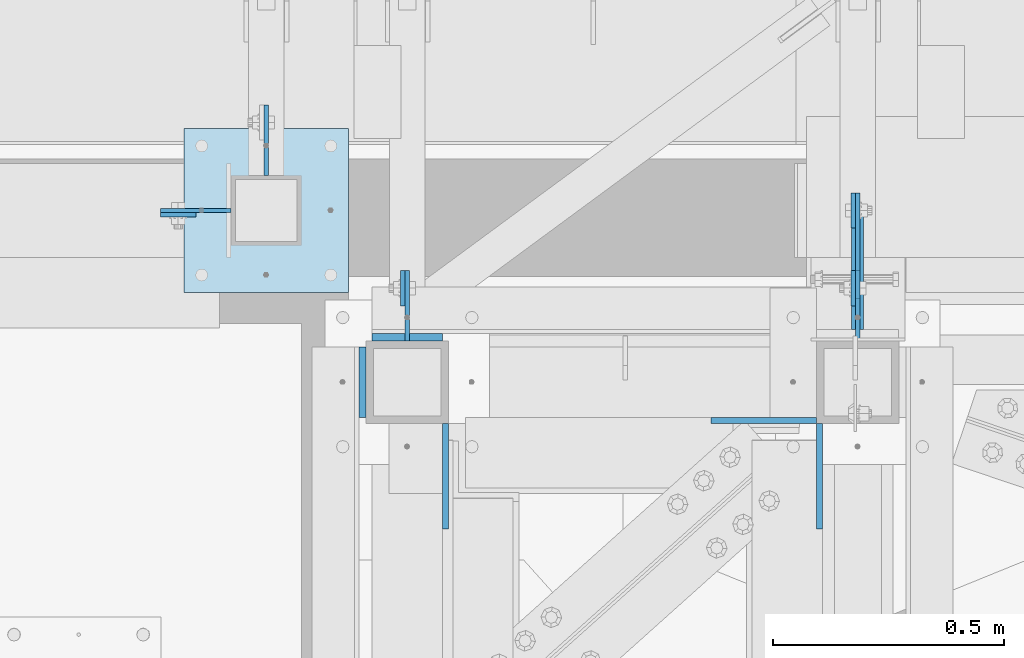
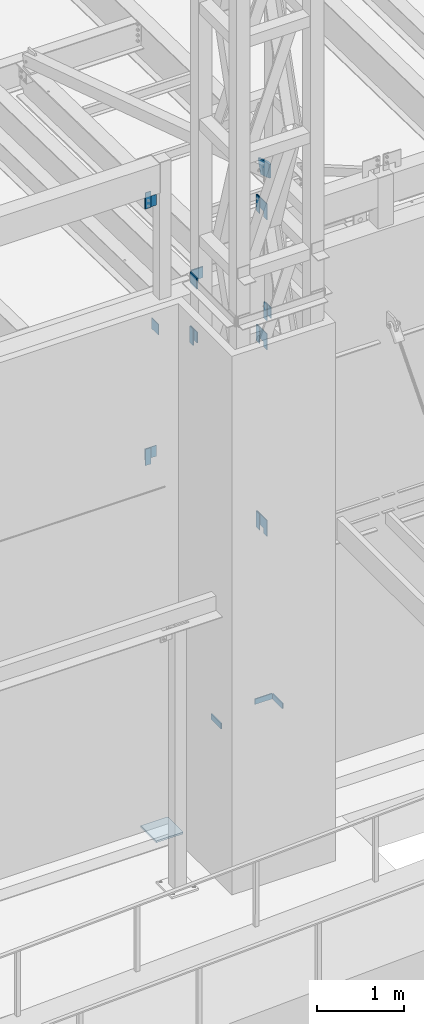
# One storey, part 1449 of 1763: 22 plates, 9 elements without a shape of their own.
"""IFC2X3 building model written with IfcOpenShell, lengths in millimetres."""

from ifc_helpers import new_model, si_unit, frame, origin_with_axes, place, context, subcontext, project, spatial, faceted_brep, material, type_object, element, aggregate, save


model = new_model("IFC2X3")

# Units and contexts
model_context = context("Model", 3, precision=1e-05, world=origin_with_axes())
body_context = subcontext(model_context, "Body", "Model", "MODEL_VIEW")
ifc_project = project(units=[si_unit("LENGTHUNIT", "METRE", prefix="MILLI"), si_unit("AREAUNIT", "SQUARE_METRE"), si_unit("VOLUMEUNIT", "CUBIC_METRE"), si_unit("MASSUNIT", "GRAM", prefix="KILO"), si_unit("TIMEUNIT", "SECOND"), si_unit("PLANEANGLEUNIT", "RADIAN"), si_unit("SOLIDANGLEUNIT", "STERADIAN"), si_unit("THERMODYNAMICTEMPERATUREUNIT", "DEGREE_CELSIUS"), si_unit("LUMINOUSINTENSITYUNIT", "LUMEN")], contexts=[model_context])

# Site, building, storey
site_placement = place(None, origin_with_axes())
site = spatial("IfcSite", under=ifc_project, at=site_placement, CompositionType="ELEMENT")
building_placement = place(site_placement, origin_with_axes())
building = spatial("IfcBuilding", under=site, at=building_placement, Name="Undefined", CompositionType="ELEMENT")
storey_placement = place(building_placement, origin_with_axes())
storey = spatial("IfcBuildingStorey", under=building, at=storey_placement, Name="Undefined", CompositionType="ELEMENT", Elevation=0.0)

# Assembly, plates
assembly_1_placement = place(storey_placement, origin_with_axes())
assembly_1 = element("IfcElementAssembly", 1, at=assembly_1_placement, inside=storey, Name="FRAME", AssemblyPlace="NOTDEFINED", PredefinedType="RIGID_FRAME")
ifc_material = material(Name="STEEL/A36")
plate_type_1 = type_object("IfcPlateType", PredefinedType="NOTDEFINED")
plate_1_placement = place(assembly_1_placement, frame((-63528.0023996443, -14662.1507542366, 6845.29999694824), z_axis=(0.99999999999718, 2.37500000002911e-06, 0.0), x_axis=(0.0, 0.0, -1.0)))
plate_1 = element("IfcPlate", 2, at=plate_1_placement, type_object=plate_type_1, material=ifc_material, Name="PLATE", context=body_context, shape_type="Brep", body=[
    faceted_brep([(0.0, -6.34999999999491, 1.45519152283669e-11), (0.0, -6.35000000001855, 228.600006104178), (0.0, 6.34999999996944, 228.600006104134), (0.0, 6.34999999999491, -2.91038304567337e-11), (76.1999969482422, -6.35000000001855, 228.600006104178), (76.1999969482422, 6.34999999996944, 228.600006104134), (76.1999969482422, -6.34999999999491, 1.45519152283669e-11), (76.1999969482422, 6.34999999999491, -2.91038304567337e-11)], [[[0, 1, 2, 3]], [[1, 4, 5, 2]], [[4, 6, 7, 5]], [[6, 0, 3, 7]], [[5, 7, 3, 2]], [[6, 4, 1, 0]]]),
])
plate_2_placement = place(assembly_1_placement, frame((-64102.6775957006, -14897.1023151462, 6845.29999694824), z_axis=(0.0, 1.0, 0.0), x_axis=(0.0, 0.0, -1.0)))
plate_2 = element("IfcPlate", 3, at=plate_2_placement, type_object=plate_type_1, material=ifc_material, Name="PLATE", context=body_context, shape_type="Brep", body=[
    faceted_brep([(0.0, -6.34999999999491, 1.45519152283669e-11), (0.0, -6.35000000001855, 228.600006104178), (0.0, 6.34999999996944, 228.600006104134), (0.0, 6.34999999999491, -2.91038304567337e-11), (76.1999969482422, -6.35000000001855, 228.600006104178), (76.1999969482422, 6.34999999996944, 228.600006104134), (76.1999969482422, -6.34999999999491, 1.45519152283669e-11), (76.1999969482422, 6.34999999999491, -2.91038304567337e-11)], [[[0, 1, 2, 3]], [[1, 4, 5, 2]], [[4, 6, 7, 5]], [[6, 0, 3, 7]], [[5, 7, 3, 2]], [[6, 4, 1, 0]]]),
])
plate_3_placement = place(assembly_1_placement, frame((-63293.0525956311, -14897.1023151462, 6845.29999694824), z_axis=(0.0, 1.0, 0.0), x_axis=(0.0, 0.0, -1.0)))
plate_3 = element("IfcPlate", 4, at=plate_3_placement, type_object=plate_type_1, material=ifc_material, Name="PLATE", context=body_context, shape_type="Brep", body=[
    faceted_brep([(0.0, -6.34999999999491, 1.45519152283669e-11), (0.0, -6.35000000001855, 228.600006104178), (0.0, 6.34999999996944, 228.600006104134), (0.0, 6.34999999999491, -2.91038304567337e-11), (76.1999969482422, -6.35000000001855, 228.600006104178), (76.1999969482422, 6.34999999996944, 228.600006104134), (76.1999969482422, -6.34999999999491, 1.45519152283669e-11), (76.1999969482422, 6.34999999999491, -2.91038304567337e-11)], [[[0, 1, 2, 3]], [[1, 4, 5, 2]], [[4, 6, 7, 5]], [[6, 0, 3, 7]], [[5, 7, 3, 2]], [[6, 4, 1, 0]]]),
])

# Assembly, plate
assembly_2_placement = place(storey_placement, origin_with_axes())
assembly_2 = element("IfcElementAssembly", 5, at=assembly_2_placement, inside=storey, Name="BEAM", AssemblyPlace="NOTDEFINED", PredefinedType="RIGID_FRAME")
plate_type_2 = type_object("IfcPlateType", PredefinedType="NOTDEFINED")
plate_4_placement = place(assembly_2_placement, frame((-64642.88272792, -14217.6514913088, 14058.9), z_axis=(0.0, 0.0, -1.0), x_axis=(-1.0, 0.0, 0.0)))
plate_4 = element("IfcPlate", 6, at=plate_4_placement, type_object=plate_type_2, material=ifc_material, Name="PLATE", context=body_context, shape_type="Brep", body=[
    faceted_brep([(0.0, -4.76249999999982, 0.0), (-2.83762346953154e-10, -4.7624999996915, 228.600006103516), (-2.83762346953154e-10, 4.76250000028813, 228.600006103517), (0.0, 4.76249999999982, 0.0), (76.1999969480166, -4.76249999961874, 228.600006103516), (76.1999969480166, 4.76250000036089, 228.600006103517), (76.1999969482931, -4.76249999991705, 0.0), (76.1999969482931, 4.76250000006257, 1.81898940354586e-12)], [[[0, 1, 2, 3]], [[1, 4, 5, 2]], [[4, 6, 7, 5]], [[6, 0, 3, 7]], [[5, 7, 3, 2]], [[6, 4, 1, 0]]]),
])
aggregate(assembly_2, [plate_4])

assembly_3_placement = place(storey_placement, origin_with_axes())
assembly_3 = element("IfcElementAssembly", 7, at=assembly_3_placement, inside=storey, Name="BEAM", AssemblyPlace="NOTDEFINED", PredefinedType="RIGID_FRAME")
plate_5_placement = place(assembly_3_placement, frame((-64642.882386028, -14217.6514930879, 10248.9), z_axis=(0.0, 0.0, 1.0), x_axis=(-1.0, 0.0, 0.0)))
plate_5 = element("IfcPlate", 8, at=plate_5_placement, type_object=plate_type_2, material=ifc_material, Name="PLATE", context=body_context, shape_type="Brep", body=[
    faceted_brep([(0.0, -4.76249999999982, 0.0), (-2.83762346953154e-10, -4.7624999996915, 228.600006103516), (-2.83762346953154e-10, 4.76250000028813, 228.600006103517), (0.0, 4.76249999999982, 0.0), (76.1999969480166, -4.76249999961874, 228.600006103516), (76.1999969480166, 4.76250000036089, 228.600006103517), (76.1999969482931, -4.76249999991705, 0.0), (76.1999969482931, 4.76250000006257, 1.81898940354586e-12)], [[[0, 1, 2, 3]], [[1, 4, 5, 2]], [[4, 6, 7, 5]], [[6, 0, 3, 7]], [[5, 7, 3, 2]], [[6, 4, 1, 0]]]),
])
aggregate(assembly_3, [plate_5])

assembly_4_placement = place(storey_placement, origin_with_axes())
assembly_4 = element("IfcElementAssembly", 9, at=assembly_4_placement, inside=storey, Name="BEAM", AssemblyPlace="NOTDEFINED", PredefinedType="RIGID_FRAME")
plate_6_placement = place(assembly_4_placement, frame((-64194.7527927126, -14414.5023029868, 11863.3875), z_axis=(0.0, 0.0, 1.0), x_axis=(0.0, 1.0, 0.0)))
plate_6 = element("IfcPlate", 10, at=plate_6_placement, type_object=plate_type_2, material=ifc_material, Name="PLATE", context=body_context, shape_type="Brep", body=[
    faceted_brep([(0.0, -4.76249999999982, 0.0), (-2.83762346953154e-10, -4.7624999996915, 228.600006103516), (-2.83762346953154e-10, 4.76250000028813, 228.600006103517), (0.0, 4.76249999999982, 0.0), (76.1999969480166, -4.76249999961874, 228.600006103516), (76.1999969480166, 4.76250000036089, 228.600006103517), (76.1999969482931, -4.76249999991705, 0.0), (76.1999969482931, 4.76250000006257, 1.81898940354586e-12)], [[[0, 1, 2, 3]], [[1, 4, 5, 2]], [[4, 6, 7, 5]], [[6, 0, 3, 7]], [[5, 7, 3, 2]], [[6, 4, 1, 0]]]),
])
aggregate(assembly_4, [plate_6])

assembly_5_placement = place(storey_placement, origin_with_axes())
assembly_5 = element("IfcElementAssembly", 11, at=assembly_5_placement, inside=storey, Name="BEAM", AssemblyPlace="NOTDEFINED", PredefinedType="RIGID_FRAME")
plate_7_placement = place(assembly_5_placement, frame((-63220.0275974001, -14414.5023029868, 11863.3875), z_axis=(0.0, 0.0, 1.0), x_axis=(0.0, 1.0, 0.0)))
plate_7 = element("IfcPlate", 12, at=plate_7_placement, type_object=plate_type_2, material=ifc_material, Name="PLATE", context=body_context, shape_type="Brep", body=[
    faceted_brep([(0.0, -4.76249999999982, 0.0), (-2.83762346953154e-10, -4.7624999996915, 228.600006103516), (-2.83762346953154e-10, 4.76250000028813, 228.600006103517), (0.0, 4.76249999999982, 0.0), (76.1999969480166, -4.76249999961874, 228.600006103516), (76.1999969480166, 4.76250000036089, 228.600006103517), (76.1999969482931, -4.76249999991705, 0.0), (76.1999969482931, 4.76250000006257, 1.81898940354586e-12)], [[[0, 1, 2, 3]], [[1, 4, 5, 2]], [[4, 6, 7, 5]], [[6, 0, 3, 7]], [[5, 7, 3, 2]], [[6, 4, 1, 0]]]),
])
aggregate(assembly_5, [plate_7])

assembly_6_placement = place(storey_placement, origin_with_axes())
assembly_6 = element("IfcElementAssembly", 13, at=assembly_6_placement, inside=storey, Name="BEAM", AssemblyPlace="NOTDEFINED", PredefinedType="RIGID_FRAME")
plate_8_placement = place(assembly_6_placement, frame((-63220.0271949537, -14170.0272208131, 8839.2), z_axis=(0.0, 0.0, 1.0), x_axis=(0.0, -1.0, 0.0)))
plate_8 = element("IfcPlate", 14, at=plate_8_placement, type_object=plate_type_2, material=ifc_material, Name="PLATE", context=body_context, shape_type="Brep", body=[
    faceted_brep([(0.0, -4.76249999999982, 0.0), (-2.83762346953154e-10, -4.7624999996915, 228.600006103516), (-2.83762346953154e-10, 4.76250000028813, 228.600006103517), (0.0, 4.76249999999982, 0.0), (76.1999969480166, -4.76249999961874, 228.600006103516), (76.1999969480166, 4.76250000036089, 228.600006103517), (76.1999969482931, -4.76249999991705, 0.0), (76.1999969482931, 4.76250000006257, 1.81898940354586e-12)], [[[0, 1, 2, 3]], [[1, 4, 5, 2]], [[4, 6, 7, 5]], [[6, 0, 3, 7]], [[5, 7, 3, 2]], [[6, 4, 1, 0]]]),
])
aggregate(assembly_6, [plate_8])

assembly_7_placement = place(storey_placement, origin_with_axes())
assembly_7 = element("IfcElementAssembly", 15, at=assembly_7_placement, inside=storey, Name="BEAM", AssemblyPlace="NOTDEFINED", PredefinedType="RIGID_FRAME")
plate_9_placement = place(assembly_7_placement, frame((-63220.0271950283, -14170.0272553227, 11442.7), z_axis=(0.0, 0.0, 1.0), x_axis=(0.0, -1.0, 0.0)))
plate_9 = element("IfcPlate", 16, at=plate_9_placement, type_object=plate_type_2, material=ifc_material, Name="PLATE", context=body_context, shape_type="Brep", body=[
    faceted_brep([(0.0, -4.76249999999982, 0.0), (-2.83762346953154e-10, -4.7624999996915, 228.600006103516), (-2.83762346953154e-10, 4.76250000028813, 228.600006103517), (0.0, 4.76249999999982, 0.0), (76.1999969480166, -4.76249999961874, 228.600006103516), (76.1999969480166, 4.76250000036089, 228.600006103517), (76.1999969482931, -4.76249999991705, 0.0), (76.1999969482931, 4.76250000006257, 1.81898940354586e-12)], [[[0, 1, 2, 3]], [[1, 4, 5, 2]], [[4, 6, 7, 5]], [[6, 0, 3, 7]], [[5, 7, 3, 2]], [[6, 4, 1, 0]]]),
])
aggregate(assembly_7, [plate_9])

assembly_8_placement = place(storey_placement, origin_with_axes())
assembly_8 = element("IfcElementAssembly", 17, at=assembly_8_placement, inside=storey, Name="BEAM", AssemblyPlace="NOTDEFINED", PredefinedType="RIGID_FRAME")
plate_10_placement = place(assembly_8_placement, frame((-63220.0271949362, -14170.0272553227, 13258.8221257957), z_axis=(0.0, 0.0, 1.0), x_axis=(0.0, -1.0, 0.0)))
plate_10 = element("IfcPlate", 18, at=plate_10_placement, type_object=plate_type_2, material=ifc_material, Name="PLATE", context=body_context, shape_type="Brep", body=[
    faceted_brep([(0.0, -4.76249999999982, 0.0), (-2.83762346953154e-10, -4.7624999996915, 228.600006103516), (-2.83762346953154e-10, 4.76250000028813, 228.600006103517), (0.0, 4.76249999999982, 0.0), (76.1999969480166, -4.76249999961874, 228.600006103516), (76.1999969480166, 4.76250000036089, 228.600006103517), (76.1999969482931, -4.76249999991705, 0.0), (76.1999969482931, 4.76250000006257, 1.81898940354586e-12)], [[[0, 1, 2, 3]], [[1, 4, 5, 2]], [[4, 6, 7, 5]], [[6, 0, 3, 7]], [[5, 7, 3, 2]], [[6, 4, 1, 0]]]),
])
aggregate(assembly_8, [plate_10])

# Plate
plate_type_3 = type_object("IfcPlateType", PredefinedType="NOTDEFINED")
plate_11_placement = place(assembly_1_placement, frame((-63210.5021924388, -14398.6345957664, 9067.75577032242), z_axis=(-4.00000135414302e-09, 9.67160000327568e-05, -0.999999995323008), x_axis=(-1.2000009728941e-08, 0.999999995323008, 9.67160000319667e-05)))
plate_11 = element("IfcPlate", 19, at=plate_11_placement, type_object=plate_type_3, material=ifc_material, Name="PLATE", context=body_context, shape_type="Brep", body=[
    faceted_brep([(0.0, -4.76249999999982, 0.0), (-0.0147415312894736, -4.76250000055734, 228.577880859459), (-0.0147415312967496, 4.76249999946594, 228.577880859457), (0.0, 4.76249999999982, 0.0), (76.1926269535688, -4.76250000031723, 228.563140869262), (76.1926269535616, 4.76249999970605, 228.563140869261), (76.1999969485987, -4.76250000013533, 152.385253906345), (76.1999969485914, 4.76249999988795, 152.385253906343), (228.59263610909, -4.76249999964057, 152.399993896655), (228.592636109082, 4.76250000037544, 152.399993896655), (228.607376099128, -4.76249999928405, 2.14640749618411e-10), (228.607376099135, 4.76250000073924, 2.12821760214865e-10)], [[[0, 1, 2, 3]], [[1, 4, 5, 2]], [[4, 6, 7, 5]], [[6, 8, 9, 7]], [[8, 10, 11, 9]], [[10, 0, 3, 11]], [[5, 7, 9, 11, 3, 2]], [[10, 8, 6, 4, 1, 0]]]),
])

plate_12_placement = place(assembly_1_placement, frame((-63210.5021882652, -14398.6346302753, 11671.2557703224), z_axis=(-4.00000135414302e-09, 9.67160000327568e-05, -0.999999995323008), x_axis=(-1.2000009728941e-08, 0.999999995323008, 9.67160000319667e-05)))
plate_12 = element("IfcPlate", 20, at=plate_12_placement, type_object=plate_type_3, material=ifc_material, Name="PLATE", context=body_context, shape_type="Brep", body=[
    faceted_brep([(0.0, -4.76249999999982, 0.0), (-0.0147415312894736, -4.76250000055734, 228.577880859459), (-0.0147415312967496, 4.76249999946594, 228.577880859457), (0.0, 4.76249999999982, 0.0), (76.1926269535688, -4.76250000031723, 228.563140869262), (76.1926269535616, 4.76249999970605, 228.563140869261), (76.1999969485987, -4.76250000013533, 152.385253906345), (76.1999969485914, 4.76249999988795, 152.385253906343), (228.59263610909, -4.76249999964057, 152.399993896655), (228.592636109082, 4.76250000037544, 152.399993896655), (228.607376099128, -4.76249999928405, 2.14640749618411e-10), (228.607376099135, 4.76250000073924, 2.12821760214865e-10)], [[[0, 1, 2, 3]], [[1, 4, 5, 2]], [[4, 6, 7, 5]], [[6, 8, 9, 7]], [[8, 10, 11, 9]], [[10, 0, 3, 11]], [[5, 7, 9, 11, 3, 2]], [[10, 8, 6, 4, 1, 0]]]),
])

plate_13_placement = place(assembly_1_placement, frame((-63210.5021924212, -14398.6346302757, 13487.3778961182), z_axis=(-4.00000135414302e-09, 9.67160000327568e-05, -0.999999995323008), x_axis=(-1.2000009728941e-08, 0.999999995323008, 9.67160000319667e-05)))
plate_13 = element("IfcPlate", 21, at=plate_13_placement, type_object=plate_type_3, material=ifc_material, Name="PLATE", context=body_context, shape_type="Brep", body=[
    faceted_brep([(0.0, -4.76249999999982, 0.0), (-0.0147415312894736, -4.76250000055734, 228.577880859459), (-0.0147415312967496, 4.76249999946594, 228.577880859457), (0.0, 4.76249999999982, 0.0), (76.1926269535688, -4.76250000031723, 228.563140869262), (76.1926269535616, 4.76249999970605, 228.563140869261), (76.1999969485987, -4.76250000013533, 152.385253906345), (76.1999969485914, 4.76249999988795, 152.385253906343), (228.59263610909, -4.76249999964057, 152.399993896655), (228.592636109082, 4.76250000037544, 152.399993896655), (228.607376099128, -4.76249999928405, 2.14640749618411e-10), (228.607376099135, 4.76250000073924, 2.12821760214865e-10)], [[[0, 1, 2, 3]], [[1, 4, 5, 2]], [[4, 6, 7, 5]], [[6, 8, 9, 7]], [[8, 10, 11, 9]], [[10, 0, 3, 11]], [[5, 7, 9, 11, 3, 2]], [[10, 8, 6, 4, 1, 0]]]),
])

# Assembly, plates
assembly_9_placement = place(storey_placement, origin_with_axes())
assembly_9 = element("IfcElementAssembly", 22, at=assembly_9_placement, inside=storey, Name="COLUMN", AssemblyPlace="NOTDEFINED", PredefinedType="RIGID_FRAME")
plate_type_4 = type_object("IfcPlateType", PredefinedType="NOTDEFINED")
plate_14_placement = place(assembly_9_placement, frame((-64719.0827248207, -14208.126492046, 13830.2999938965), z_axis=(0.0, 0.0, 1.0), x_axis=(1.0, 0.0, 0.0)))
plate_14 = element("IfcPlate", 23, at=plate_14_placement, type_object=plate_type_4, material=ifc_material, Name="PLATE", context=body_context, shape_type="Brep", body=[
    faceted_brep([(0.0, -4.76249999999982, 0.0), (-3.05175672110636e-06, -4.7625000002663, 152.399993896484), (-3.05175490211695e-06, 4.76249999972788, 152.399993896484), (0.0, 4.76249999999982, 0.0), (152.400009155272, -4.76249999975698, 152.399993896484), (152.400009155273, 4.76250000024447, 152.399993896484), (152.400009155272, -4.76249999948777, 5.45696821063757e-12), (152.400009155273, 4.76250000051368, 3.63797880709171e-12)], [[[0, 1, 2, 3]], [[1, 4, 5, 2]], [[4, 6, 7, 5]], [[6, 0, 3, 7]], [[5, 7, 3, 2]], [[6, 4, 1, 0]]]),
])
plate_15_placement = place(assembly_9_placement, frame((-64490.4821819791, -13979.5264678355, 12091.9875061035), z_axis=(0.0, 0.0, -1.0), x_axis=(0.0, -1.0, 0.0)))
plate_15 = element("IfcPlate", 24, at=plate_15_placement, type_object=plate_type_4, material=ifc_material, Name="PLATE", context=body_context, shape_type="Brep", body=[
    faceted_brep([(0.0, -4.76249999999982, 0.0), (-3.05175672110636e-06, -4.7625000002663, 152.399993896484), (-3.05175490211695e-06, 4.76249999972788, 152.399993896484), (0.0, 4.76249999999982, 0.0), (152.400009155272, -4.76249999975698, 152.399993896484), (152.400009155273, 4.76250000024447, 152.399993896484), (152.400009155272, -4.76249999948777, 5.45696821063757e-12), (152.400009155273, 4.76250000051368, 3.63797880709171e-12)], [[[0, 1, 2, 3]], [[1, 4, 5, 2]], [[4, 6, 7, 5]], [[6, 0, 3, 7]], [[5, 7, 3, 2]], [[6, 4, 1, 0]]]),
])
plate_16_placement = place(assembly_9_placement, frame((-64719.0823830238, -14208.1264945876, 10477.5000061035), z_axis=(0.0, 0.0, -1.0), x_axis=(1.0, 0.0, 0.0)))
plate_16 = element("IfcPlate", 25, at=plate_16_placement, type_object=plate_type_4, material=ifc_material, Name="PLATE", context=body_context, shape_type="Brep", body=[
    faceted_brep([(0.0, -4.76249999999982, 0.0), (-3.05175672110636e-06, -4.7625000002663, 152.399993896484), (-3.05175490211695e-06, 4.76249999972788, 152.399993896484), (0.0, 4.76249999999982, 0.0), (152.400009155272, -4.76249999975698, 152.399993896484), (152.400009155273, 4.76250000024447, 152.399993896484), (152.400009155272, -4.76249999948777, 5.45696821063757e-12), (152.400009155273, 4.76250000051368, 3.63797880709171e-12)], [[[0, 1, 2, 3]], [[1, 4, 5, 2]], [[4, 6, 7, 5]], [[6, 0, 3, 7]], [[5, 7, 3, 2]], [[6, 4, 1, 0]]]),
])

# Plate
plate_17_placement = place(assembly_1_placement, frame((-63210.5025989001, -14338.302305991, 12091.9875061035), z_axis=(0.0, 0.0, -1.0), x_axis=(0.0, -1.0, 0.0)))
plate_17 = element("IfcPlate", 26, at=plate_17_placement, type_object=plate_type_4, material=ifc_material, Name="PLATE", context=body_context, shape_type="Brep", body=[
    faceted_brep([(0.0, -4.76249999999982, 0.0), (-3.05175672110636e-06, -4.7625000002663, 152.399993896484), (-3.05175490211695e-06, 4.76249999972788, 152.399993896484), (0.0, 4.76249999999982, 0.0), (152.400009155272, -4.76249999975698, 152.399993896484), (152.400009155273, 4.76250000024447, 152.399993896484), (152.400009155272, -4.76249999948777, 5.45696821063757e-12), (152.400009155273, 4.76250000051368, 3.63797880709171e-12)], [[[0, 1, 2, 3]], [[1, 4, 5, 2]], [[4, 6, 7, 5]], [[6, 0, 3, 7]], [[5, 7, 3, 2]], [[6, 4, 1, 0]]]),
])

plate_18_placement = place(assembly_1_placement, frame((-64185.2277942127, -14338.302305991, 12091.9875061035), z_axis=(0.0, 0.0, -1.0), x_axis=(0.0, -1.0, 0.0)))
plate_18 = element("IfcPlate", 27, at=plate_18_placement, type_object=plate_type_4, material=ifc_material, Name="PLATE", context=body_context, shape_type="Brep", body=[
    faceted_brep([(0.0, -4.76249999999982, 0.0), (-3.05175672110636e-06, -4.7625000002663, 152.399993896484), (-3.05175490211695e-06, 4.76249999972788, 152.399993896484), (0.0, 4.76249999999982, 0.0), (152.400009155272, -4.76249999975698, 152.399993896484), (152.400009155273, 4.76250000024447, 152.399993896484), (152.400009155272, -4.76249999948777, 5.45696821063757e-12), (152.400009155273, 4.76250000051368, 3.63797880709171e-12)], [[[0, 1, 2, 3]], [[1, 4, 5, 2]], [[4, 6, 7, 5]], [[6, 0, 3, 7]], [[5, 7, 3, 2]], [[6, 4, 1, 0]]]),
])

plate_type_5 = type_object("IfcPlateType", PredefinedType="NOTDEFINED")
plate_19_placement = place(assembly_1_placement, frame((-63211.0608225783, -14465.3023149687, 14078.6557910015), z_axis=(0.0, 0.0, -1.0), x_axis=(0.0, 1.0, 0.0)))
plate_19 = element("IfcPlate", 28, at=plate_19_placement, type_object=plate_type_5, material=ifc_material, Name="PLATE", context=body_context, shape_type="Brep", body=[
    faceted_brep([(0.0, -12.6999999999971, -1.81898940354586e-12), (3.61378624802455e-08, -12.6999999999971, 191.819641113281), (3.61378624802455e-08, 12.6999999999971, 191.819641113281), (0.0, 12.6999999999971, -1.81898940354586e-12), (198.309204101633, -12.6999999999971, 255.740051269475), (198.309204101633, 12.6999999999971, 255.740051269475), (260.647735595721, -12.6999999999971, 62.3385391234624), (260.647735595721, 12.6999999999971, 62.3385391234624), (67.246223449707, -12.6999999999971, -2.36468622460961e-11), (67.246223449707, 12.6999999999971, -2.36468622460961e-11)], [[[0, 1, 2, 3]], [[1, 4, 5, 2]], [[4, 6, 7, 5]], [[6, 8, 9, 7]], [[8, 0, 3, 9]], [[5, 7, 9, 3, 2]], [[8, 6, 4, 1, 0]]]),
])

plate_type_6 = type_object("IfcPlateType", PredefinedType="NOTDEFINED")
plate_20_placement = place(assembly_9_placement, frame((-64668.282374092, -14030.3264769908, 5080.0), z_axis=(1.0, 0.0, 0.0), x_axis=(0.0, -1.0, 0.0)))
plate_20 = element("IfcPlate", 29, at=plate_20_placement, type_object=plate_type_6, material=ifc_material, Name="PLATE", context=body_context, shape_type="Brep", body=[
    faceted_brep([(0.0, -12.6999999999971, -1.81898940354586e-12), (0.0, -12.6999999999998, 355.600006103516), (0.0, 12.6999999999998, 355.600006103516), (0.0, 12.6999999999971, -1.81898940354586e-12), (355.600006103516, -12.6999999999998, 355.600006103516), (355.600006103516, 12.6999999999998, 355.600006103516), (355.600006103516, -12.6999999999998, 0.0), (355.600006103516, 12.6999999999998, 0.0)], [[[0, 1, 2, 3]], [[1, 4, 5, 2]], [[4, 6, 7, 5]], [[6, 0, 3, 7]], [[5, 7, 3, 2]], [[6, 4, 1, 0]]]),
])

aggregate(assembly_9, [plate_20, plate_14, plate_15, plate_16])

plate_type_7 = type_object("IfcPlateType", PredefinedType="NOTDEFINED")
plate_21_placement = place(assembly_1_placement, frame((-64261.4277910131, -14482.7648151462, 12827.0), z_axis=(1.0, 0.0, 0.0), x_axis=(0.0, 0.0, 1.0)))
plate_21 = element("IfcPlate", 30, at=plate_21_placement, type_object=plate_type_7, material=ifc_material, Name="PLATE", context=body_context, shape_type="Brep", body=[
    faceted_brep([(-7.27595761418343e-12, -7.9375, 0.0), (7.27595761418343e-12, -7.9375, 152.399993896484), (7.27595761418343e-12, 7.9375, 152.399993896484), (-7.27595761418343e-12, 7.9375, 0.0), (152.399993896484, -7.9375, 152.399993896484), (152.399993896484, 7.9375, 152.399993896484), (152.399993896484, -7.9375, -1.81898940354586e-12), (152.399993896484, 7.9375, -1.81898940354586e-12)], [[[0, 1, 2, 3]], [[1, 4, 5, 2]], [[4, 6, 7, 5]], [[6, 0, 3, 7]], [[5, 7, 3, 2]], [[6, 4, 1, 0]]]),
])

plate_22_placement = place(assembly_1_placement, frame((-64282.0652910131, -14655.8023151462, 12979.3999938965), z_axis=(0.0, 0.0, -1.0), x_axis=(0.0, 1.0, 0.0)))
plate_22 = element("IfcPlate", 31, at=plate_22_placement, type_object=plate_type_7, material=ifc_material, Name="PLATE", context=body_context, shape_type="Brep", body=[
    faceted_brep([(-7.27595761418343e-12, -7.9375, 0.0), (7.27595761418343e-12, -7.9375, 152.399993896484), (7.27595761418343e-12, 7.9375, 152.399993896484), (-7.27595761418343e-12, 7.9375, 0.0), (152.399993896484, -7.9375, 152.399993896484), (152.399993896484, 7.9375, 152.399993896484), (152.399993896484, -7.9375, -1.81898940354586e-12), (152.399993896484, 7.9375, -1.81898940354586e-12)], [[[0, 1, 2, 3]], [[1, 4, 5, 2]], [[4, 6, 7, 5]], [[6, 0, 3, 7]], [[5, 7, 3, 2]], [[6, 4, 1, 0]]]),
])

aggregate(assembly_1, [plate_1, plate_2, plate_3, plate_19, plate_21, plate_22, plate_17, plate_18, plate_11, plate_12, plate_13])

save(model, "model.ifc")
